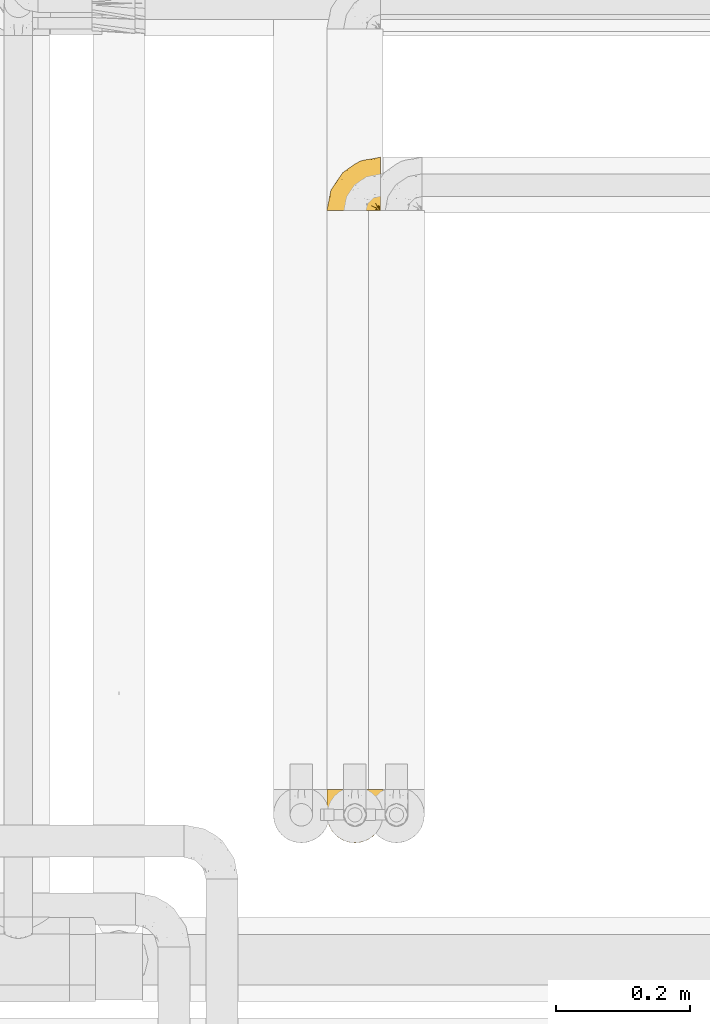
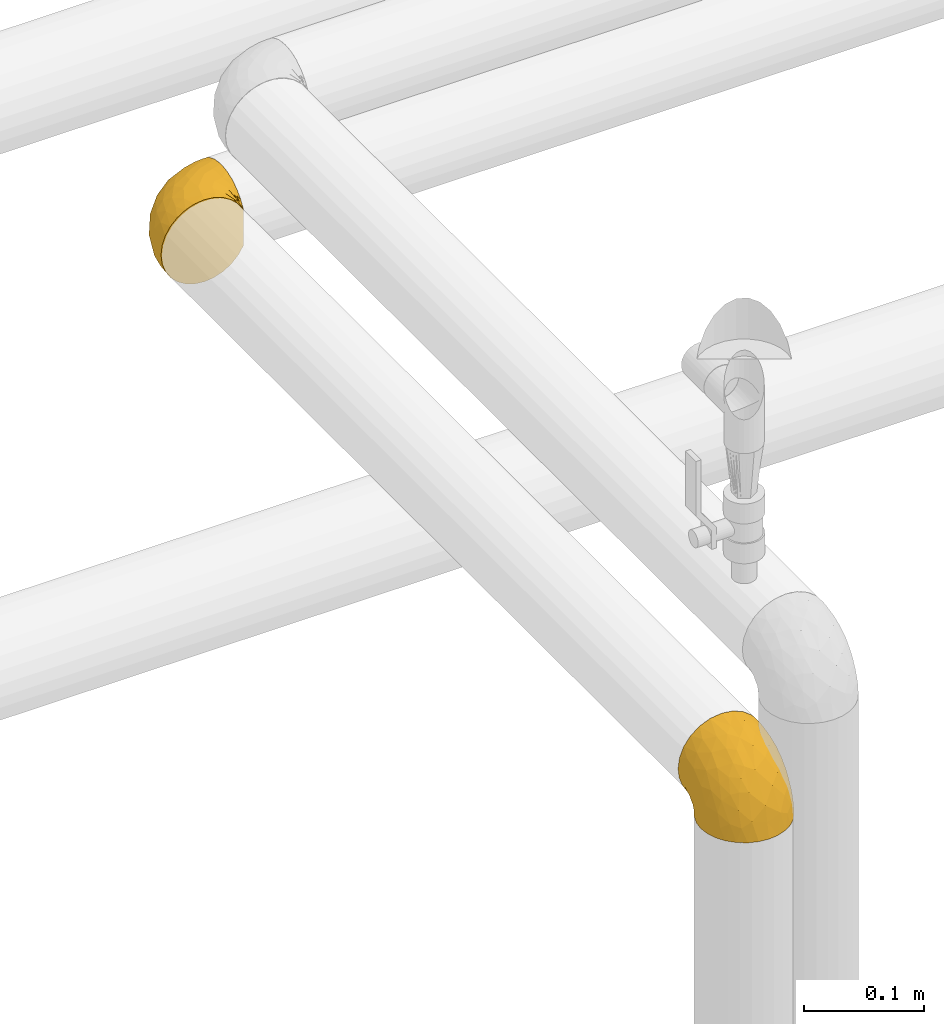
# One storey, part 425 of 827: 2 coverings.
"""IFC2X3 building model written with IfcOpenShell, lengths in millimetres."""

from ifc_helpers import new_model, entity, si_unit, converted_unit, derived_unit, direction, frame, origin, place, context, subcontext, project, spatial, faceted_brep, element, save


model = new_model("IFC2X3")

# Units and contexts
model_context = context("Model", 3, precision=0.01, world=origin(), true_north=direction((6.12303176911189e-17, 1.0)))
body_context = subcontext(model_context, "Body", "Model", "MODEL_VIEW")
ifc_project = project(units=[si_unit("LENGTHUNIT", "METRE", prefix="MILLI"), si_unit("AREAUNIT", "SQUARE_METRE"), si_unit("VOLUMEUNIT", "CUBIC_METRE"), converted_unit("PLANEANGLEUNIT", "DEGREE", entity("IfcRatioMeasure", 0.0174532925199433), si_unit("PLANEANGLEUNIT", "RADIAN"), dimensions=[0, 0, 0, 0, 0, 0, 0]), si_unit("MASSUNIT", "GRAM", prefix="KILO"), derived_unit("MASSDENSITYUNIT", [(si_unit("MASSUNIT", "GRAM", prefix="KILO"), 1), (si_unit("LENGTHUNIT", "METRE"), -3)]), derived_unit("MOMENTOFINERTIAUNIT", [(si_unit("LENGTHUNIT", "METRE"), 4)]), si_unit("TIMEUNIT", "SECOND"), si_unit("FREQUENCYUNIT", "HERTZ"), si_unit("THERMODYNAMICTEMPERATUREUNIT", "DEGREE_CELSIUS"), derived_unit("THERMALTRANSMITTANCEUNIT", [(si_unit("MASSUNIT", "GRAM", prefix="KILO"), 1), (si_unit("THERMODYNAMICTEMPERATUREUNIT", "KELVIN"), -1), (si_unit("TIMEUNIT", "SECOND"), -3)]), derived_unit("VOLUMETRICFLOWRATEUNIT", [(si_unit("LENGTHUNIT", "METRE"), 3), (si_unit("TIMEUNIT", "SECOND"), -1)]), derived_unit("MASSFLOWRATEUNIT", [(si_unit("MASSUNIT", "GRAM", prefix="KILO"), 1), (si_unit("TIMEUNIT", "SECOND"), -1)]), derived_unit("ROTATIONALFREQUENCYUNIT", [(si_unit("TIMEUNIT", "SECOND"), -1)]), si_unit("ELECTRICCURRENTUNIT", "AMPERE"), si_unit("ELECTRICVOLTAGEUNIT", "VOLT"), si_unit("POWERUNIT", "WATT"), si_unit("FORCEUNIT", "NEWTON", prefix="KILO"), si_unit("ILLUMINANCEUNIT", "LUX"), si_unit("LUMINOUSFLUXUNIT", "LUMEN"), si_unit("LUMINOUSINTENSITYUNIT", "CANDELA"), derived_unit("USERDEFINED", [(si_unit("MASSUNIT", "GRAM", prefix="KILO"), -1), (si_unit("LENGTHUNIT", "METRE"), -2), (si_unit("TIMEUNIT", "SECOND"), 3), (si_unit("LUMINOUSFLUXUNIT", "LUMEN"), 1)]), derived_unit("LINEARVELOCITYUNIT", [(si_unit("LENGTHUNIT", "METRE"), 1), (si_unit("TIMEUNIT", "SECOND"), -1)]), si_unit("PRESSUREUNIT", "PASCAL"), derived_unit("USERDEFINED", [(si_unit("LENGTHUNIT", "METRE"), -2), (si_unit("MASSUNIT", "GRAM", prefix="KILO"), 1), (si_unit("TIMEUNIT", "SECOND"), -2)]), derived_unit("LINEARFORCEUNIT", [(si_unit("MASSUNIT", "GRAM", prefix="KILO"), 1), (si_unit("LENGTHUNIT", "METRE"), 1), (si_unit("TIMEUNIT", "SECOND"), -2), (si_unit("LENGTHUNIT", "METRE"), -1)]), derived_unit("PLANARFORCEUNIT", [(si_unit("MASSUNIT", "GRAM", prefix="KILO"), 1), (si_unit("LENGTHUNIT", "METRE"), 1), (si_unit("TIMEUNIT", "SECOND"), -2), (si_unit("LENGTHUNIT", "METRE"), -2)])], contexts=[model_context])

# Site, building, storey
site_placement = place(None, origin())
site = spatial("IfcSite", under=ifc_project, at=site_placement, CompositionType="ELEMENT")
building_placement = place(site_placement, origin())
building = spatial("IfcBuilding", under=site, at=building_placement, CompositionType="ELEMENT")
storey_placement = place(building_placement, frame((0.0, 0.0, 28200.0)))
storey = spatial("IfcBuildingStorey", under=building, at=storey_placement, Name="08", CompositionType="ELEMENT", Elevation=28200.0)

# Coverings
covering_1_placement = place(storey_placement, frame((54648.74, 17188.97, 1356.55)))
element("IfcCovering", 1, at=covering_1_placement, inside=storey, Name=":ADSK_", ObjectType=":ADSK_", PredefinedType="INSULATION", context=body_context, shape_type="Brep", body=[
    faceted_brep([(25.28, 1.6, 81.15), (17.35, 1.6, 76.16), (10.72, 1.6, 69.53), (5.74, 1.6, 61.6), (2.64, 1.6, 52.75), (1.6, 1.6, 43.45), (2.65, 1.6, 34.13), (5.74, 1.6, 25.28), (10.73, 1.6, 17.35), (17.36, 1.6, 10.72), (25.29, 1.6, 5.74), (34.14, 1.6, 2.64), (43.45, 1.6, 1.6), (52.82, 1.6, 2.66), (61.71, 1.6, 5.79), (69.67, 1.6, 10.83), (76.31, 1.6, 17.53), (81.27, 1.6, 25.53), (81.27, 1.6, 26.45), (81.27, 1.6, 27.37), (81.27, 1.6, 28.17), (81.27, 1.6, 29.49), (81.27, 1.6, 30.81), (81.27, 1.6, 32.13), (81.27, 1.6, 33.45), (81.27, 1.6, 34.78), (81.27, 1.6, 36.1), (81.27, 1.6, 37.42), (81.27, 1.6, 38.74), (81.27, 1.6, 40.06), (81.27, 1.6, 41.38), (81.27, 1.6, 42.7), (81.27, 1.6, 44.02), (81.27, 1.6, 45.34), (81.27, 1.6, 46.66), (81.27, 1.6, 47.58), (81.27, 1.6, 48.5), (81.27, 1.6, 49.41), (81.27, 1.6, 50.33), (81.27, 1.6, 51.25), (81.27, 1.6, 52.17), (81.27, 1.6, 53.09), (81.27, 1.6, 54.01), (81.27, 1.6, 54.93), (81.27, 1.6, 55.85), (81.27, 1.6, 56.76), (81.27, 1.6, 57.68), (81.27, 1.6, 58.6), (81.27, 1.6, 59.52), (81.27, 1.6, 60.44), (81.27, 1.6, 61.36), (76.3, 1.6, 69.37), (69.66, 1.6, 76.07), (61.69, 1.6, 81.11), (52.8, 1.6, 84.24), (43.45, 1.6, 85.3), (34.13, 1.6, 84.24), (81.45, 6.74, 17.52), (81.45, 13.37, 10.83), (81.45, 21.34, 5.79), (81.45, 30.23, 2.66), (81.45, 39.6, 1.6), (81.45, 50.43, 3.02), (81.45, 60.52, 7.2), (81.45, 69.19, 13.85), (81.45, 75.84, 22.52), (81.45, 80.02, 32.61), (81.45, 81.45, 43.45), (81.45, 80.02, 54.28), (81.45, 75.84, 64.37), (81.45, 69.19, 73.04), (81.45, 60.52, 79.69), (81.45, 50.43, 83.87), (81.45, 39.6, 85.3), (81.45, 30.23, 84.23), (81.45, 21.34, 81.1), (81.45, 13.37, 76.06), (81.45, 6.74, 69.37), (81.45, 1.77, 61.36), (81.45, 1.77, 60.44), (81.45, 1.77, 59.12), (81.45, 1.77, 58.0), (81.45, 1.77, 56.88), (81.45, 1.77, 55.76), (81.45, 1.77, 54.64), (81.45, 1.77, 53.52), (81.45, 1.77, 52.4), (81.45, 1.77, 51.28), (81.45, 1.77, 50.16), (81.45, 1.77, 49.04), (81.45, 1.77, 47.92), (81.45, 1.77, 46.8), (81.45, 1.77, 45.68), (81.45, 1.77, 44.56), (81.45, 1.77, 43.45), (81.45, 1.77, 42.12), (81.45, 1.77, 40.8), (81.45, 1.77, 39.48), (81.45, 1.77, 38.16), (81.45, 1.77, 36.84), (81.45, 1.77, 35.52), (81.45, 1.77, 34.2), (81.45, 1.77, 32.88), (81.45, 1.77, 31.96), (81.45, 1.77, 31.05), (81.45, 1.77, 30.13), (81.45, 1.77, 29.21), (81.45, 1.77, 28.29), (81.45, 1.77, 27.37), (81.45, 1.77, 26.45), (81.45, 1.77, 25.53), (81.33, 1.73, 54.08), (81.32, 1.72, 55.16), (81.33, 1.73, 36.18), (81.32, 1.72, 35.13), (81.33, 1.73, 44.01), (81.32, 1.73, 45.08), (81.32, 1.72, 61.36), (81.32, 1.72, 59.98), (81.32, 1.72, 46.18), (81.32, 1.72, 26.74), (81.32, 1.72, 47.36), (81.32, 1.73, 29.67), (81.34, 1.74, 28.72), (81.32, 1.72, 39.77), (81.31, 1.71, 52.96), (81.33, 1.73, 51.84), (81.31, 1.71, 40.8), (81.32, 1.72, 41.87), (81.33, 1.73, 42.94), (81.32, 1.72, 27.77), (81.33, 1.73, 48.4), (81.32, 1.72, 37.21), (81.33, 1.73, 33.54), (81.32, 1.72, 32.49), (81.32, 1.72, 30.69), (81.32, 1.72, 50.69), (81.31, 1.71, 49.6), (81.32, 1.72, 56.32), (81.33, 1.73, 57.44), (81.31, 1.71, 58.88), (81.32, 1.72, 25.53), (81.3, 1.68, 61.36), (81.29, 1.64, 61.36), (81.29, 1.64, 25.53), (81.3, 1.68, 25.53), (81.4, 1.75, 61.36), (81.36, 1.74, 61.36), (81.36, 1.74, 25.53), (81.4, 1.75, 25.53), (81.3, 1.7, 31.59), (81.33, 1.73, 38.71), (74.06, 24.54, 3.97), (45.99, 11.1, 1.6), (58.35, 8.47, 3.97), (67.76, 9.11, 8.09), (66.18, 4.86, 8.09), (76.46, 5.0, 16.43), (77.33, 6.81, 15.73), (71.95, 37.05, 1.6), (72.25, 9.03, 10.79), (78.91, 9.47, 13.99), (76.42, 16.39, 8.08), (73.52, 3.95, 14.0), (76.9, 9.9, 12.83), (65.25, 22.7, 3.18), (62.45, 34.5, 1.6), (74.31, 37.68, 1.6), (59.38, 15.82, 3.28), (48.54, 20.6, 1.6), (67.72, 14.37, 6.28), (55.49, 27.55, 1.6), (79.73, 5.2, 19.06), (73.23, 14.88, 8.08), (45.36, 8.73, 1.6), (15.81, 44.27, 32.11), (6.4, 20.94, 29.62), (7.67, 32.15, 43.45), (68.46, 46.13, 2.45), (59.33, 42.67, 2.5), (48.7, 55.18, 9.73), (53.94, 67.27, 17.97), (65.02, 62.91, 10.24), (60.77, 51.5, 4.78), (72.07, 54.79, 4.78), (26.25, 25.78, 8.01), (22.29, 13.05, 8.01), (16.0, 18.46, 13.85), (46.93, 32.4, 2.42), (14.19, 31.07, 21.17), (58.46, 77.32, 35.73), (61.51, 75.62, 27.43), (4.64, 16.9, 43.45), (68.93, 71.69, 17.97), (29.62, 61.4, 35.71), (24.85, 54.47, 29.47), (38.55, 27.66, 3.41), (31.27, 14.53, 3.94), (9.35, 15.56, 21.17), (37.15, 42.26, 7.92), (47.07, 41.51, 4.25), (26.49, 36.93, 11.75), (23.01, 42.72, 18.31), (19.4, 44.68, 24.94), (48.06, 71.2, 28.78), (42.46, 70.48, 35.82), (50.89, 75.37, 43.45), (35.78, 63.65, 28.38), (24.98, 58.06, 43.45), (16.33, 45.11, 43.45), (66.14, 78.4, 43.45), (30.96, 54.95, 21.21), (41.83, 59.31, 16.48), (33.28, 49.01, 13.85), (37.94, 66.71, 43.45), (67.39, 53.75, 82.11), (58.47, 77.27, 51.41), (32.5, 61.6, 57.45), (15.79, 44.24, 54.78), (15.99, 18.46, 73.03), (9.34, 15.55, 65.7), (56.91, 60.14, 76.65), (63.5, 70.5, 68.92), (44.08, 63.0, 68.01), (26.24, 25.78, 78.88), (22.27, 13.05, 78.88), (31.26, 14.53, 82.94), (23.95, 48.5, 64.44), (63.79, 44.23, 84.49), (62.45, 34.5, 85.3), (71.95, 37.05, 85.3), (45.36, 8.73, 85.3), (67.83, 77.68, 57.84), (70.28, 64.08, 76.65), (42.11, 70.25, 51.19), (6.39, 20.93, 57.26), (43.54, 49.9, 78.14), (58.03, 49.6, 82.35), (14.18, 31.06, 65.7), (56.34, 39.62, 84.61), (48.09, 34.42, 84.36), (48.54, 20.6, 85.3), (55.49, 27.55, 85.3), (21.78, 33.36, 73.03), (38.54, 27.68, 83.48), (45.99, 11.1, 85.3), (72.79, 46.67, 84.54), (33.26, 49.0, 73.03), (35.53, 38.94, 79.54), (53.66, 73.05, 59.46), (43.03, 56.63, 73.5), (49.68, 43.85, 82.57), (74.06, 24.54, 82.92), (59.37, 15.82, 83.62), (58.34, 8.47, 82.92), (67.75, 9.12, 78.81), (78.91, 9.47, 72.9), (76.9, 9.91, 74.06), (78.08, 16.85, 78.81), (73.23, 14.88, 78.81), (79.73, 5.2, 67.83), (77.34, 6.81, 71.15), (73.51, 3.96, 72.91), (76.45, 5.0, 70.47), (66.41, 5.86, 78.81), (67.7, 14.38, 80.62), (72.24, 9.04, 76.11), (65.25, 22.7, 83.71)], [[[0, 1, 2, 3, 4, 5, 6, 7, 8, 9, 10, 11, 12, 13, 14, 15, 16, 17, 18, 19, 20, 21, 22, 23, 24, 25, 26, 27, 28, 29, 30, 31, 32, 33, 34, 35, 36, 37, 38, 39, 40, 41, 42, 43, 44, 45, 46, 47, 48, 49, 50, 51, 52, 53, 54, 55, 56]], [[57, 58, 59, 60, 61, 62, 63, 64, 65, 66, 67, 68, 69, 70, 71, 72, 73, 74, 75, 76, 77, 78, 79, 80, 81, 82, 83, 84, 85, 86, 87, 88, 89, 90, 91, 92, 93, 94, 95, 96, 97, 98, 99, 100, 101, 102, 103, 104, 105, 106, 107, 108, 109, 110]], [[111, 84, 112]], [[113, 26, 114]], [[114, 101, 100]], [[115, 93, 116]], [[79, 117, 118]], [[33, 116, 119]], [[117, 49, 118]], [[19, 18, 120]], [[119, 121, 34]], [[122, 21, 123]], [[97, 96, 124]], [[86, 125, 126]], [[116, 92, 119]], [[127, 96, 128]], [[32, 129, 115]], [[19, 120, 130]], [[121, 90, 131]], [[94, 115, 129]], [[115, 116, 32]], [[118, 49, 48]], [[113, 99, 132]], [[133, 114, 25]], [[24, 134, 133]], [[135, 22, 122]], [[136, 137, 88]], [[84, 83, 112]], [[138, 82, 139]], [[130, 20, 19]], [[118, 48, 140]], [[81, 140, 139]], [[123, 21, 20]], [[141, 120, 18]], [[139, 82, 81]], [[130, 107, 123]], [[49, 117, 142, 143, 50]], [[18, 17, 144, 145, 141]], [[79, 78, 146, 147, 117]], [[109, 141, 148, 149, 110]], [[102, 133, 134]], [[105, 135, 122]], [[118, 80, 79]], [[80, 118, 140]], [[120, 109, 108]], [[47, 46, 140, 48]], [[81, 80, 140]], [[44, 112, 138]], [[93, 115, 94]], [[46, 139, 140]], [[46, 45, 139]], [[139, 45, 138]], [[138, 112, 83]], [[85, 84, 111]], [[112, 43, 111]], [[83, 82, 138]], [[106, 122, 123]], [[105, 122, 106]], [[21, 122, 22]], [[124, 29, 28]], [[33, 32, 116]], [[128, 129, 31]], [[32, 31, 129]], [[34, 33, 119]], [[116, 93, 92]], [[129, 95, 94]], [[95, 129, 128]], [[41, 40, 125, 42]], [[119, 91, 121]], [[36, 35, 131, 37]], [[137, 131, 89]], [[121, 131, 35]], [[90, 121, 91]], [[119, 92, 91]], [[136, 126, 39]], [[125, 86, 85]], [[42, 125, 111]], [[85, 111, 125]], [[150, 23, 22]], [[130, 108, 107]], [[130, 123, 20]], [[107, 106, 123]], [[137, 37, 131]], [[136, 38, 137]], [[89, 88, 137]], [[131, 90, 89]], [[124, 151, 97]], [[40, 39, 126]], [[87, 126, 136]], [[86, 126, 87]], [[136, 88, 87]], [[40, 126, 125]], [[39, 38, 136]], [[95, 128, 96]], [[30, 128, 31]], [[29, 124, 127]], [[127, 128, 30]], [[151, 124, 28]], [[127, 30, 29]], [[127, 124, 96]], [[151, 98, 97]], [[45, 44, 138]], [[26, 113, 132]], [[113, 100, 99]], [[132, 151, 27]], [[27, 26, 132]], [[26, 25, 114]], [[100, 113, 114]], [[101, 133, 102]], [[133, 101, 114]], [[28, 27, 151]], [[132, 99, 98]], [[23, 134, 24]], [[25, 24, 133]], [[134, 23, 150]], [[135, 104, 150]], [[150, 104, 103]], [[103, 102, 134]], [[130, 120, 108]], [[109, 120, 141]], [[42, 111, 43]], [[112, 44, 43]], [[104, 135, 105]], [[134, 150, 103]], [[135, 150, 22]], [[35, 34, 121]], [[137, 38, 37]], [[98, 151, 132]], [[59, 152, 60]], [[13, 153, 154]], [[155, 156, 154]], [[157, 158, 141]], [[159, 60, 152]], [[160, 157, 155]], [[161, 162, 58]], [[58, 162, 59]], [[144, 16, 163]], [[58, 57, 161]], [[162, 161, 164]], [[157, 163, 155]], [[163, 16, 15]], [[57, 149, 161]], [[152, 165, 166]], [[157, 144, 163]], [[60, 159, 167, 61]], [[156, 14, 154]], [[163, 156, 155]], [[155, 154, 168]], [[168, 154, 169]], [[155, 170, 160]], [[57, 110, 149]], [[144, 17, 16]], [[156, 15, 14]], [[171, 165, 168]], [[158, 164, 172]], [[14, 13, 154]], [[157, 141, 145, 144]], [[173, 164, 158]], [[173, 160, 170]], [[171, 166, 165]], [[168, 165, 170]], [[168, 169, 171]], [[152, 173, 165]], [[170, 155, 168]], [[165, 173, 170]], [[160, 173, 158]], [[172, 149, 148]], [[148, 141, 158]], [[158, 157, 160]], [[152, 166, 159]], [[173, 152, 162]], [[59, 162, 152]], [[13, 12, 174, 153]], [[153, 169, 154]], [[15, 156, 163]], [[162, 164, 173]], [[172, 164, 161]], [[149, 172, 161]], [[158, 172, 148]], [[175, 176, 177]], [[178, 166, 179]], [[180, 181, 182]], [[183, 184, 178]], [[185, 186, 187]], [[171, 188, 179]], [[174, 12, 11]], [[189, 176, 175]], [[190, 66, 191]], [[176, 6, 192]], [[193, 65, 64]], [[63, 184, 182]], [[63, 182, 64]], [[65, 193, 191]], [[184, 63, 62]], [[175, 194, 195]], [[196, 169, 197]], [[174, 11, 197]], [[8, 7, 198]], [[187, 9, 8]], [[197, 169, 153, 174]], [[197, 11, 10]], [[186, 197, 10]], [[199, 180, 200]], [[197, 185, 196]], [[201, 189, 202]], [[201, 187, 189]], [[195, 203, 175]], [[191, 204, 190]], [[176, 7, 6]], [[177, 176, 192]], [[189, 198, 176]], [[65, 191, 66]], [[198, 187, 8]], [[205, 206, 190]], [[9, 186, 10]], [[181, 207, 204]], [[208, 175, 177, 209]], [[66, 190, 210]], [[211, 212, 213]], [[190, 204, 205]], [[180, 182, 183]], [[193, 182, 181]], [[62, 61, 167]], [[196, 185, 199]], [[196, 200, 188]], [[6, 5, 192]], [[176, 198, 7]], [[187, 198, 189]], [[187, 186, 9]], [[197, 186, 185]], [[200, 180, 183]], [[180, 213, 212]], [[179, 183, 178]], [[185, 201, 199]], [[210, 190, 206]], [[210, 67, 66]], [[205, 204, 207]], [[194, 205, 207]], [[194, 214, 205]], [[195, 194, 207]], [[208, 194, 175]], [[207, 211, 195]], [[202, 203, 211]], [[212, 207, 181]], [[202, 211, 213]], [[201, 202, 213]], [[189, 175, 203]], [[199, 201, 213]], [[187, 201, 185]], [[180, 199, 213]], [[196, 199, 200]], [[211, 203, 195]], [[189, 203, 202]], [[207, 212, 211]], [[180, 212, 181]], [[214, 194, 208]], [[214, 206, 205]], [[196, 188, 169]], [[181, 204, 191]], [[182, 193, 64]], [[191, 193, 181]], [[178, 62, 167]], [[182, 184, 183]], [[62, 178, 184]], [[178, 167, 159, 166]], [[171, 179, 166]], [[200, 183, 179]], [[179, 188, 200]], [[169, 188, 171]], [[71, 215, 72]], [[206, 216, 210]], [[217, 208, 218]], [[216, 68, 210]], [[219, 220, 2]], [[221, 222, 223]], [[224, 225, 226]], [[227, 223, 217]], [[228, 229, 230]], [[56, 231, 226]], [[232, 222, 69]], [[56, 55, 231]], [[70, 233, 71]], [[71, 233, 215]], [[0, 56, 226]], [[208, 217, 234]], [[218, 177, 235]], [[221, 236, 237]], [[238, 220, 219]], [[1, 219, 2]], [[68, 216, 232]], [[235, 3, 220]], [[235, 192, 4]], [[1, 0, 225]], [[228, 239, 229]], [[240, 241, 242]], [[243, 238, 219]], [[224, 226, 244]], [[226, 241, 244]], [[3, 235, 4]], [[69, 222, 70]], [[225, 219, 1]], [[218, 235, 238]], [[243, 219, 224]], [[218, 227, 217]], [[3, 2, 220]], [[218, 208, 209, 177]], [[226, 231, 245, 241]], [[215, 228, 246]], [[247, 248, 236]], [[248, 224, 244]], [[223, 222, 249]], [[233, 222, 221]], [[242, 239, 240]], [[248, 247, 243]], [[217, 223, 249]], [[250, 247, 236]], [[216, 234, 249]], [[218, 238, 227]], [[192, 235, 177]], [[192, 5, 4]], [[72, 246, 73]], [[235, 220, 238]], [[226, 225, 0]], [[219, 225, 224]], [[240, 248, 244]], [[239, 242, 229]], [[236, 248, 251]], [[68, 67, 210]], [[234, 216, 206]], [[216, 249, 232]], [[234, 206, 214, 208]], [[249, 234, 217]], [[222, 232, 249]], [[69, 68, 232]], [[246, 228, 230]], [[237, 228, 215]], [[243, 227, 238]], [[223, 227, 247]], [[73, 246, 230]], [[215, 246, 72]], [[248, 243, 224]], [[227, 243, 247]], [[237, 236, 251]], [[250, 221, 223]], [[222, 233, 70]], [[215, 233, 221]], [[221, 237, 215]], [[239, 237, 251]], [[237, 239, 228]], [[239, 251, 240]], [[248, 240, 251]], [[241, 240, 244]], [[221, 250, 236]], [[223, 247, 250]], [[74, 230, 252]], [[253, 254, 255]], [[146, 77, 256]], [[257, 258, 259]], [[260, 256, 257]], [[260, 261, 147]], [[75, 74, 252]], [[51, 143, 262]], [[263, 143, 142, 117]], [[256, 77, 76]], [[252, 258, 75]], [[253, 241, 254]], [[254, 245, 54]], [[258, 256, 76]], [[53, 52, 264]], [[255, 265, 253]], [[254, 264, 255]], [[255, 264, 262]], [[75, 258, 76]], [[265, 255, 266]], [[255, 262, 263]], [[51, 50, 143]], [[54, 245, 231, 55]], [[51, 262, 52]], [[253, 267, 242]], [[254, 54, 53]], [[266, 259, 265]], [[146, 78, 77]], [[263, 117, 261]], [[146, 256, 260]], [[257, 259, 261]], [[267, 253, 265]], [[229, 267, 252]], [[242, 267, 229]], [[242, 241, 253]], [[252, 267, 259]], [[255, 263, 266]], [[259, 267, 265]], [[261, 117, 147]], [[263, 261, 266]], [[259, 266, 261]], [[230, 74, 73]], [[230, 229, 252]], [[259, 258, 252]], [[254, 241, 245]], [[53, 264, 254]], [[52, 262, 264]], [[143, 263, 262]], [[258, 257, 256]], [[261, 260, 257]], [[146, 260, 147]]]),
])
covering_2_placement = place(storey_placement, frame((54648.74, 16245.12, 1360.4)))
element("IfcCovering", 2, at=covering_2_placement, inside=storey, Name=":ADSK_", ObjectType=":ADSK_", PredefinedType="INSULATION", context=body_context, shape_type="Brep", body=[
    faceted_brep([(81.15, 25.28, 1.6), (76.16, 17.35, 1.6), (69.53, 10.72, 1.6), (61.6, 5.74, 1.6), (52.75, 2.64, 1.6), (43.45, 1.6, 1.6), (34.13, 2.65, 1.6), (25.28, 5.74, 1.6), (17.35, 10.73, 1.6), (10.72, 17.36, 1.6), (5.74, 25.29, 1.6), (2.64, 34.14, 1.6), (1.6, 43.45, 1.6), (2.66, 52.82, 1.6), (5.79, 61.71, 1.6), (10.83, 69.67, 1.6), (17.53, 76.31, 1.6), (25.53, 81.27, 1.6), (26.45, 81.27, 1.6), (27.37, 81.27, 1.6), (28.17, 81.27, 1.6), (29.49, 81.27, 1.6), (30.81, 81.27, 1.6), (32.13, 81.27, 1.6), (33.45, 81.27, 1.6), (34.78, 81.27, 1.6), (36.1, 81.27, 1.6), (37.42, 81.27, 1.6), (38.74, 81.27, 1.6), (40.06, 81.27, 1.6), (41.38, 81.27, 1.6), (42.7, 81.27, 1.6), (44.02, 81.27, 1.6), (45.34, 81.27, 1.6), (46.66, 81.27, 1.6), (47.58, 81.27, 1.6), (48.5, 81.27, 1.6), (49.41, 81.27, 1.6), (50.33, 81.27, 1.6), (51.25, 81.27, 1.6), (52.17, 81.27, 1.6), (53.09, 81.27, 1.6), (54.01, 81.27, 1.6), (54.93, 81.27, 1.6), (55.85, 81.27, 1.6), (56.76, 81.27, 1.6), (57.68, 81.27, 1.6), (58.6, 81.27, 1.6), (59.52, 81.27, 1.6), (60.44, 81.27, 1.6), (61.36, 81.27, 1.6), (69.37, 76.3, 1.6), (76.07, 69.66, 1.6), (81.11, 61.69, 1.6), (84.24, 52.8, 1.6), (85.3, 43.45, 1.6), (84.24, 34.13, 1.6), (17.52, 81.45, 6.74), (10.83, 81.45, 13.37), (5.79, 81.45, 21.34), (2.66, 81.45, 30.23), (1.6, 81.45, 39.6), (3.02, 81.45, 50.43), (7.2, 81.45, 60.52), (13.85, 81.45, 69.19), (22.52, 81.45, 75.84), (32.61, 81.45, 80.02), (43.45, 81.45, 81.45), (54.28, 81.45, 80.02), (64.37, 81.45, 75.84), (73.04, 81.45, 69.19), (79.69, 81.45, 60.52), (83.87, 81.45, 50.43), (85.3, 81.45, 39.6), (84.23, 81.45, 30.23), (81.1, 81.45, 21.34), (76.06, 81.45, 13.37), (69.37, 81.45, 6.74), (61.36, 81.45, 1.77), (60.44, 81.45, 1.77), (59.12, 81.45, 1.77), (58.0, 81.45, 1.77), (56.88, 81.45, 1.77), (55.76, 81.45, 1.77), (54.64, 81.45, 1.77), (53.52, 81.45, 1.77), (52.4, 81.45, 1.77), (51.28, 81.45, 1.77), (50.16, 81.45, 1.77), (49.04, 81.45, 1.77), (47.92, 81.45, 1.77), (46.8, 81.45, 1.77), (45.68, 81.45, 1.77), (44.56, 81.45, 1.77), (43.45, 81.45, 1.77), (42.12, 81.45, 1.77), (40.8, 81.45, 1.77), (39.48, 81.45, 1.77), (38.16, 81.45, 1.77), (36.84, 81.45, 1.77), (35.52, 81.45, 1.77), (34.2, 81.45, 1.77), (32.88, 81.45, 1.77), (31.96, 81.45, 1.77), (31.05, 81.45, 1.77), (30.13, 81.45, 1.77), (29.21, 81.45, 1.77), (28.29, 81.45, 1.77), (27.37, 81.45, 1.77), (26.45, 81.45, 1.77), (25.53, 81.45, 1.77), (54.08, 81.33, 1.73), (55.16, 81.32, 1.72), (36.18, 81.33, 1.73), (35.13, 81.32, 1.72), (44.01, 81.33, 1.73), (45.08, 81.32, 1.73), (61.36, 81.32, 1.72), (59.98, 81.32, 1.72), (46.18, 81.32, 1.72), (26.74, 81.32, 1.72), (47.36, 81.32, 1.72), (29.67, 81.32, 1.73), (28.72, 81.34, 1.74), (39.77, 81.32, 1.72), (52.96, 81.31, 1.71), (51.84, 81.33, 1.73), (40.8, 81.31, 1.71), (41.87, 81.32, 1.72), (42.94, 81.33, 1.73), (27.77, 81.32, 1.72), (48.4, 81.33, 1.73), (37.21, 81.32, 1.72), (33.54, 81.33, 1.73), (32.49, 81.32, 1.72), (30.69, 81.32, 1.72), (50.69, 81.32, 1.72), (49.6, 81.31, 1.71), (56.32, 81.32, 1.72), (57.44, 81.33, 1.73), (58.88, 81.31, 1.71), (25.53, 81.32, 1.72), (61.36, 81.3, 1.68), (61.36, 81.29, 1.64), (25.53, 81.29, 1.64), (25.53, 81.3, 1.68), (61.36, 81.4, 1.75), (61.36, 81.36, 1.74), (25.53, 81.36, 1.74), (25.53, 81.4, 1.75), (31.59, 81.3, 1.7), (38.71, 81.33, 1.73), (3.97, 74.06, 24.54), (1.6, 45.99, 11.1), (3.97, 58.35, 8.47), (8.09, 67.76, 9.11), (8.09, 66.18, 4.86), (16.43, 76.46, 5.0), (15.73, 77.33, 6.81), (1.6, 71.95, 37.05), (10.79, 72.25, 9.03), (13.99, 78.91, 9.47), (8.08, 76.42, 16.39), (14.0, 73.52, 3.95), (12.83, 76.9, 9.9), (3.18, 65.25, 22.7), (1.6, 62.45, 34.5), (1.6, 74.31, 37.68), (3.28, 59.38, 15.82), (1.6, 48.54, 20.6), (6.28, 67.72, 14.37), (1.6, 55.49, 27.55), (19.06, 79.73, 5.2), (8.08, 73.23, 14.88), (1.6, 45.36, 8.73), (32.11, 15.81, 44.27), (29.62, 6.4, 20.94), (43.45, 7.67, 32.15), (2.45, 68.46, 46.13), (2.5, 59.33, 42.67), (9.73, 48.7, 55.18), (17.97, 53.94, 67.27), (10.24, 65.02, 62.91), (4.78, 60.77, 51.5), (4.78, 72.07, 54.79), (8.01, 26.25, 25.78), (8.01, 22.29, 13.05), (13.85, 16.0, 18.46), (2.42, 46.93, 32.4), (21.17, 14.19, 31.07), (35.73, 58.46, 77.32), (27.43, 61.51, 75.62), (43.45, 4.64, 16.9), (17.97, 68.93, 71.69), (35.71, 29.62, 61.4), (29.47, 24.85, 54.47), (3.41, 38.55, 27.66), (3.94, 31.27, 14.53), (21.17, 9.35, 15.56), (7.92, 37.15, 42.26), (4.25, 47.07, 41.51), (11.75, 26.49, 36.93), (18.31, 23.01, 42.72), (24.94, 19.4, 44.68), (28.78, 48.06, 71.2), (35.82, 42.46, 70.48), (43.45, 50.89, 75.37), (28.38, 35.78, 63.65), (43.45, 24.98, 58.06), (43.45, 16.33, 45.11), (43.45, 66.14, 78.4), (21.21, 30.96, 54.95), (16.48, 41.83, 59.31), (13.85, 33.28, 49.01), (43.45, 37.94, 66.71), (82.11, 67.39, 53.75), (51.41, 58.47, 77.27), (57.45, 32.5, 61.6), (54.78, 15.79, 44.24), (73.03, 15.99, 18.46), (65.7, 9.34, 15.55), (76.65, 56.91, 60.14), (68.92, 63.5, 70.5), (68.01, 44.08, 63.0), (78.88, 26.24, 25.78), (78.88, 22.27, 13.05), (82.94, 31.26, 14.53), (64.44, 23.95, 48.5), (84.49, 63.79, 44.23), (85.3, 62.45, 34.5), (85.3, 71.95, 37.05), (85.3, 45.36, 8.73), (57.84, 67.83, 77.68), (76.65, 70.28, 64.08), (51.19, 42.11, 70.25), (57.26, 6.39, 20.93), (78.14, 43.54, 49.9), (82.35, 58.03, 49.6), (65.7, 14.18, 31.06), (84.61, 56.34, 39.62), (84.36, 48.09, 34.42), (85.3, 48.54, 20.6), (85.3, 55.49, 27.55), (73.03, 21.78, 33.36), (83.48, 38.54, 27.68), (85.3, 45.99, 11.1), (84.54, 72.79, 46.67), (73.03, 33.26, 49.0), (79.54, 35.53, 38.94), (59.46, 53.66, 73.05), (73.5, 43.03, 56.63), (82.57, 49.68, 43.85), (82.92, 74.06, 24.54), (83.62, 59.37, 15.82), (82.92, 58.34, 8.47), (78.81, 67.75, 9.12), (72.9, 78.91, 9.47), (74.06, 76.9, 9.91), (78.81, 78.08, 16.85), (78.81, 73.23, 14.88), (67.83, 79.73, 5.2), (71.15, 77.34, 6.81), (72.91, 73.51, 3.96), (70.47, 76.45, 5.0), (78.81, 66.41, 5.86), (80.62, 67.7, 14.38), (76.11, 72.24, 9.04), (83.71, 65.25, 22.7)], [[[0, 1, 2, 3, 4, 5, 6, 7, 8, 9, 10, 11, 12, 13, 14, 15, 16, 17, 18, 19, 20, 21, 22, 23, 24, 25, 26, 27, 28, 29, 30, 31, 32, 33, 34, 35, 36, 37, 38, 39, 40, 41, 42, 43, 44, 45, 46, 47, 48, 49, 50, 51, 52, 53, 54, 55, 56]], [[57, 58, 59, 60, 61, 62, 63, 64, 65, 66, 67, 68, 69, 70, 71, 72, 73, 74, 75, 76, 77, 78, 79, 80, 81, 82, 83, 84, 85, 86, 87, 88, 89, 90, 91, 92, 93, 94, 95, 96, 97, 98, 99, 100, 101, 102, 103, 104, 105, 106, 107, 108, 109, 110]], [[111, 84, 112]], [[113, 26, 114]], [[114, 101, 100]], [[115, 93, 116]], [[79, 117, 118]], [[33, 116, 119]], [[117, 49, 118]], [[19, 18, 120]], [[119, 121, 34]], [[122, 21, 123]], [[97, 96, 124]], [[86, 125, 126]], [[116, 92, 119]], [[127, 96, 128]], [[32, 129, 115]], [[19, 120, 130]], [[121, 90, 131]], [[94, 115, 129]], [[115, 116, 32]], [[118, 49, 48]], [[113, 99, 132]], [[133, 114, 25]], [[24, 134, 133]], [[135, 22, 122]], [[136, 137, 88]], [[84, 83, 112]], [[138, 82, 139]], [[130, 20, 19]], [[118, 48, 140]], [[81, 140, 139]], [[123, 21, 20]], [[141, 120, 18]], [[139, 82, 81]], [[130, 107, 123]], [[49, 117, 142, 143, 50]], [[18, 17, 144, 145, 141]], [[79, 78, 146, 147, 117]], [[109, 141, 148, 149, 110]], [[102, 133, 134]], [[105, 135, 122]], [[118, 80, 79]], [[80, 118, 140]], [[120, 109, 108]], [[47, 46, 140, 48]], [[81, 80, 140]], [[44, 112, 138]], [[93, 115, 94]], [[46, 139, 140]], [[46, 45, 139]], [[139, 45, 138]], [[138, 112, 83]], [[85, 84, 111]], [[112, 43, 111]], [[83, 82, 138]], [[106, 122, 123]], [[105, 122, 106]], [[21, 122, 22]], [[124, 29, 28]], [[33, 32, 116]], [[128, 129, 31]], [[32, 31, 129]], [[34, 33, 119]], [[116, 93, 92]], [[129, 95, 94]], [[95, 129, 128]], [[41, 40, 125, 42]], [[119, 91, 121]], [[36, 35, 131, 37]], [[137, 131, 89]], [[121, 131, 35]], [[90, 121, 91]], [[119, 92, 91]], [[136, 126, 39]], [[125, 86, 85]], [[42, 125, 111]], [[85, 111, 125]], [[150, 23, 22]], [[130, 108, 107]], [[130, 123, 20]], [[107, 106, 123]], [[137, 37, 131]], [[136, 38, 137]], [[89, 88, 137]], [[131, 90, 89]], [[124, 151, 97]], [[40, 39, 126]], [[87, 126, 136]], [[86, 126, 87]], [[136, 88, 87]], [[40, 126, 125]], [[39, 38, 136]], [[95, 128, 96]], [[30, 128, 31]], [[29, 124, 127]], [[127, 128, 30]], [[151, 124, 28]], [[127, 30, 29]], [[127, 124, 96]], [[151, 98, 97]], [[45, 44, 138]], [[26, 113, 132]], [[113, 100, 99]], [[132, 151, 27]], [[27, 26, 132]], [[26, 25, 114]], [[100, 113, 114]], [[101, 133, 102]], [[133, 101, 114]], [[28, 27, 151]], [[132, 99, 98]], [[23, 134, 24]], [[25, 24, 133]], [[134, 23, 150]], [[135, 104, 150]], [[150, 104, 103]], [[103, 102, 134]], [[130, 120, 108]], [[109, 120, 141]], [[42, 111, 43]], [[112, 44, 43]], [[104, 135, 105]], [[134, 150, 103]], [[135, 150, 22]], [[35, 34, 121]], [[137, 38, 37]], [[98, 151, 132]], [[59, 152, 60]], [[13, 153, 154]], [[155, 156, 154]], [[157, 158, 141]], [[159, 60, 152]], [[160, 157, 155]], [[161, 162, 58]], [[58, 162, 59]], [[144, 16, 163]], [[58, 57, 161]], [[162, 161, 164]], [[157, 163, 155]], [[163, 16, 15]], [[57, 149, 161]], [[152, 165, 166]], [[157, 144, 163]], [[60, 159, 167, 61]], [[156, 14, 154]], [[163, 156, 155]], [[155, 154, 168]], [[168, 154, 169]], [[155, 170, 160]], [[57, 110, 149]], [[144, 17, 16]], [[156, 15, 14]], [[171, 165, 168]], [[158, 164, 172]], [[14, 13, 154]], [[157, 141, 145, 144]], [[173, 164, 158]], [[173, 160, 170]], [[171, 166, 165]], [[168, 165, 170]], [[168, 169, 171]], [[152, 173, 165]], [[170, 155, 168]], [[165, 173, 170]], [[160, 173, 158]], [[172, 149, 148]], [[148, 141, 158]], [[158, 157, 160]], [[152, 166, 159]], [[173, 152, 162]], [[59, 162, 152]], [[13, 12, 174, 153]], [[153, 169, 154]], [[15, 156, 163]], [[162, 164, 173]], [[172, 164, 161]], [[149, 172, 161]], [[158, 172, 148]], [[175, 176, 177]], [[178, 166, 179]], [[180, 181, 182]], [[183, 184, 178]], [[185, 186, 187]], [[171, 188, 179]], [[174, 12, 11]], [[189, 176, 175]], [[190, 66, 191]], [[176, 6, 192]], [[193, 65, 64]], [[63, 184, 182]], [[63, 182, 64]], [[65, 193, 191]], [[184, 63, 62]], [[175, 194, 195]], [[196, 169, 197]], [[174, 11, 197]], [[8, 7, 198]], [[187, 9, 8]], [[197, 169, 153, 174]], [[197, 11, 10]], [[186, 197, 10]], [[199, 180, 200]], [[197, 185, 196]], [[201, 189, 202]], [[201, 187, 189]], [[195, 203, 175]], [[191, 204, 190]], [[176, 7, 6]], [[177, 176, 192]], [[189, 198, 176]], [[65, 191, 66]], [[198, 187, 8]], [[205, 206, 190]], [[9, 186, 10]], [[181, 207, 204]], [[208, 175, 177, 209]], [[66, 190, 210]], [[211, 212, 213]], [[190, 204, 205]], [[180, 182, 183]], [[193, 182, 181]], [[62, 61, 167]], [[196, 185, 199]], [[196, 200, 188]], [[6, 5, 192]], [[176, 198, 7]], [[187, 198, 189]], [[187, 186, 9]], [[197, 186, 185]], [[200, 180, 183]], [[180, 213, 212]], [[179, 183, 178]], [[185, 201, 199]], [[210, 190, 206]], [[210, 67, 66]], [[205, 204, 207]], [[194, 205, 207]], [[194, 214, 205]], [[195, 194, 207]], [[208, 194, 175]], [[207, 211, 195]], [[202, 203, 211]], [[212, 207, 181]], [[202, 211, 213]], [[201, 202, 213]], [[189, 175, 203]], [[199, 201, 213]], [[187, 201, 185]], [[180, 199, 213]], [[196, 199, 200]], [[211, 203, 195]], [[189, 203, 202]], [[207, 212, 211]], [[180, 212, 181]], [[214, 194, 208]], [[214, 206, 205]], [[196, 188, 169]], [[181, 204, 191]], [[182, 193, 64]], [[191, 193, 181]], [[178, 62, 167]], [[182, 184, 183]], [[62, 178, 184]], [[178, 167, 159, 166]], [[171, 179, 166]], [[200, 183, 179]], [[179, 188, 200]], [[169, 188, 171]], [[71, 215, 72]], [[206, 216, 210]], [[217, 208, 218]], [[216, 68, 210]], [[219, 220, 2]], [[221, 222, 223]], [[224, 225, 226]], [[227, 223, 217]], [[228, 229, 230]], [[56, 231, 226]], [[232, 222, 69]], [[56, 55, 231]], [[70, 233, 71]], [[71, 233, 215]], [[0, 56, 226]], [[208, 217, 234]], [[218, 177, 235]], [[221, 236, 237]], [[238, 220, 219]], [[1, 219, 2]], [[68, 216, 232]], [[235, 3, 220]], [[235, 192, 4]], [[1, 0, 225]], [[228, 239, 229]], [[240, 241, 242]], [[243, 238, 219]], [[224, 226, 244]], [[226, 241, 244]], [[3, 235, 4]], [[69, 222, 70]], [[225, 219, 1]], [[218, 235, 238]], [[243, 219, 224]], [[218, 227, 217]], [[3, 2, 220]], [[218, 208, 209, 177]], [[226, 231, 245, 241]], [[215, 228, 246]], [[247, 248, 236]], [[248, 224, 244]], [[223, 222, 249]], [[233, 222, 221]], [[242, 239, 240]], [[248, 247, 243]], [[217, 223, 249]], [[250, 247, 236]], [[216, 234, 249]], [[218, 238, 227]], [[192, 235, 177]], [[192, 5, 4]], [[72, 246, 73]], [[235, 220, 238]], [[226, 225, 0]], [[219, 225, 224]], [[240, 248, 244]], [[239, 242, 229]], [[236, 248, 251]], [[68, 67, 210]], [[234, 216, 206]], [[216, 249, 232]], [[234, 206, 214, 208]], [[249, 234, 217]], [[222, 232, 249]], [[69, 68, 232]], [[246, 228, 230]], [[237, 228, 215]], [[243, 227, 238]], [[223, 227, 247]], [[73, 246, 230]], [[215, 246, 72]], [[248, 243, 224]], [[227, 243, 247]], [[237, 236, 251]], [[250, 221, 223]], [[222, 233, 70]], [[215, 233, 221]], [[221, 237, 215]], [[239, 237, 251]], [[237, 239, 228]], [[239, 251, 240]], [[248, 240, 251]], [[241, 240, 244]], [[221, 250, 236]], [[223, 247, 250]], [[74, 230, 252]], [[253, 254, 255]], [[146, 77, 256]], [[257, 258, 259]], [[260, 256, 257]], [[260, 261, 147]], [[75, 74, 252]], [[51, 143, 262]], [[263, 143, 142, 117]], [[256, 77, 76]], [[252, 258, 75]], [[253, 241, 254]], [[254, 245, 54]], [[258, 256, 76]], [[53, 52, 264]], [[255, 265, 253]], [[254, 264, 255]], [[255, 264, 262]], [[75, 258, 76]], [[265, 255, 266]], [[255, 262, 263]], [[51, 50, 143]], [[54, 245, 231, 55]], [[51, 262, 52]], [[253, 267, 242]], [[254, 54, 53]], [[266, 259, 265]], [[146, 78, 77]], [[263, 117, 261]], [[146, 256, 260]], [[257, 259, 261]], [[267, 253, 265]], [[229, 267, 252]], [[242, 267, 229]], [[242, 241, 253]], [[252, 267, 259]], [[255, 263, 266]], [[259, 267, 265]], [[261, 117, 147]], [[263, 261, 266]], [[259, 266, 261]], [[230, 74, 73]], [[230, 229, 252]], [[259, 258, 252]], [[254, 241, 245]], [[53, 264, 254]], [[52, 262, 264]], [[143, 263, 262]], [[258, 257, 256]], [[261, 260, 257]], [[146, 260, 147]]]),
])

save(model, "model.ifc")
